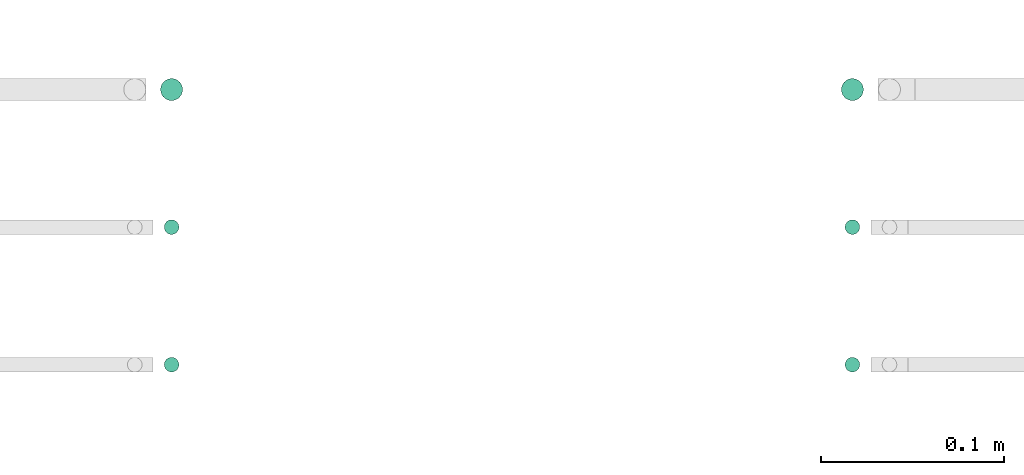
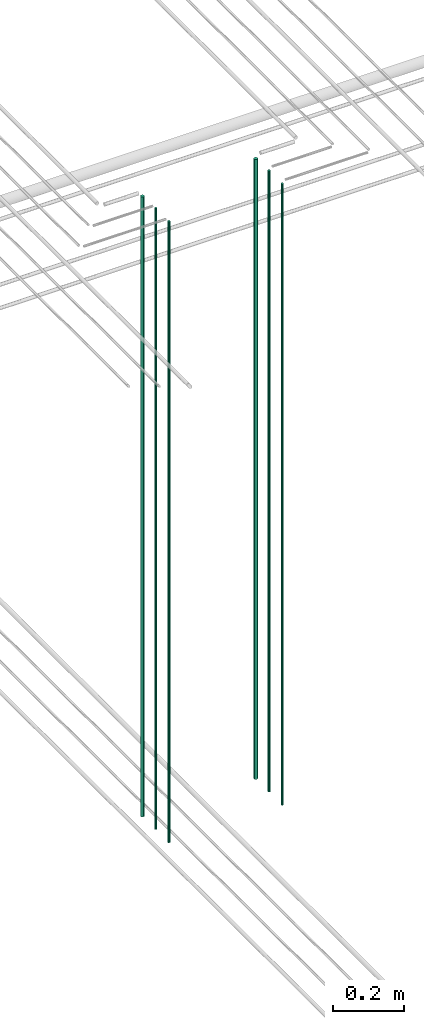
# One storey, part 11 of 331: 6 flow segments.
"""IFC2X3 building model written with IfcOpenShell, lengths in millimetres."""

import ifcopenshell
import ifcopenshell.guid

model = None  # the IFC model being written
_history = None  # IfcOwnerHistory: only IFC2X3 demands one
_inside = {}  # id of a spatial element -> (the spatial element, [elements in it])
_under = {}  # id of a project, library or spatial element -> (it, [spatial elements below it])
_declared = {}  # id of a project -> (the project, [libraries it declares])
_typed = {}  # id of a type object -> (the type object, [elements of that type])
_made_of = {}  # id of a material, layer set ... -> (it, [elements and type objects made of it])


def new_model(schema):
    """Start an empty IFC model of exactly this schema.

    Asked for "IFC4X3", IfcOpenShell would pick the latest addendum, in which some entities
    have other attributes; the version numbers below select the first issue.
    IFC2X3 requires an IfcOwnerHistory on every rooted entity: one is made here for all.
    """
    global model, _history
    if schema == "IFC4X3":
        model = ifcopenshell.file(schema_version=(4, 3, 0, 0))
    else:
        model = ifcopenshell.file(schema=schema)
    _inside.clear()
    _under.clear()
    _declared.clear()
    _typed.clear()
    _made_of.clear()
    _history = None
    if model.schema == "IFC2X3":
        org = make("IfcOrganization", Name="unknown")
        user = make(
            "IfcPersonAndOrganization",
            ThePerson=make("IfcPerson", FamilyName="unknown"),
            TheOrganization=org,
        )
        app = make(
            "IfcApplication",
            ApplicationDeveloper=org,
            Version="unknown",
            ApplicationFullName="unknown",
            ApplicationIdentifier="unknown",
        )
        _history = make(
            "IfcOwnerHistory",
            OwningUser=user,
            OwningApplication=app,
            ChangeAction="ADDED",
            CreationDate=0,
        )
    return model


def make(cls, **values):
    """One entity of the class cls with the attributes given. An attribute that is None is left unset."""
    return model.create_entity(
        cls, **{name: value for name, value in values.items() if value is not None}
    )


def entity(cls, *values):
    """Any entity or typed value of the class cls, its attributes in the order of the schema. None: left unset."""
    e = model.create_entity(cls)
    for i, value in enumerate(values):
        if value is not None:
            e[i] = value
    return e


def rooted(cls, **values):
    """An entity with a GlobalId (a new one), such as an element, a storey or a relation."""
    return make(cls, GlobalId=ifcopenshell.guid.new(), OwnerHistory=_history, **values)


def si_unit(unit_type, name, prefix=None):
    """IfcSIUnit, for example si_unit("LENGTHUNIT", "METRE", prefix="MILLI")."""
    return make("IfcSIUnit", UnitType=unit_type, Prefix=prefix, Name=name)


def converted_unit(unit_type, name, factor, base, dimensions=None, offset=None):
    """IfcConversionBasedUnit, such as the inch: factor (a typed value) times the base unit."""
    return make(
        "IfcConversionBasedUnit"
        if offset is None
        else "IfcConversionBasedUnitWithOffset",
        ConversionOffset=offset,
        Dimensions=None
        if dimensions is None
        else entity("IfcDimensionalExponents", *dimensions),
        UnitType=unit_type,
        Name=name,
        ConversionFactor=make(
            "IfcMeasureWithUnit", ValueComponent=factor, UnitComponent=base
        ),
    )


def derived_unit(unit_type, elements):
    """IfcDerivedUnit: a product of units, each with its exponent."""
    return make(
        "IfcDerivedUnit",
        Elements=[
            make("IfcDerivedUnitElement", Unit=unit, Exponent=power)
            for unit, power in elements
        ],
        UnitType=unit_type,
    )


def assignment(units):
    """IfcUnitAssignment: the units of a project."""
    return None if units is None else make("IfcUnitAssignment", Units=units)


def point(xyz):
    """IfcCartesianPoint."""
    return None if xyz is None else make("IfcCartesianPoint", Coordinates=xyz)


def direction(xyz):
    """IfcDirection."""
    return None if xyz is None else make("IfcDirection", DirectionRatios=xyz)


def frame(location, z_axis=None, x_axis=None):
    """IfcAxis2Placement3D, a coordinate frame: its origin and axes. An axis left out is left unset."""
    return make(
        "IfcAxis2Placement3D",
        Location=point(location),
        Axis=direction(z_axis),
        RefDirection=direction(x_axis),
    )


def frame_2d(location, x_axis=None):
    """IfcAxis2Placement2D, a coordinate frame in the plane: its origin and x axis."""
    return make(
        "IfcAxis2Placement2D", Location=point(location), RefDirection=direction(x_axis)
    )


def origin():
    """The frame at (0, 0, 0) with its axes left unset."""
    return frame((0.0, 0.0, 0.0))


def origin_2d_with_axis():
    """The frame at (0, 0) in the plane with the x axis (1, 0) written out."""
    return frame_2d((0.0, 0.0), x_axis=(1.0, 0.0))


def place(relative_to, where):
    """IfcLocalPlacement: puts the frame where relative to a parent placement (None: the world)."""
    return make(
        "IfcLocalPlacement", PlacementRelTo=relative_to, RelativePlacement=where
    )


def context(
    kind, dimensions, precision=None, world=None, true_north=None, identifier=None
):
    """IfcGeometricRepresentationContext, for example the 3D "Model" context."""
    return make(
        "IfcGeometricRepresentationContext",
        ContextIdentifier=identifier,
        ContextType=kind,
        CoordinateSpaceDimension=dimensions,
        Precision=precision,
        WorldCoordinateSystem=world,
        TrueNorth=true_north,
    )


def subcontext(parent, identifier, kind, view, scale=None):
    """IfcGeometricRepresentationSubContext, for example "Body" below "Model"."""
    return make(
        "IfcGeometricRepresentationSubContext",
        ContextIdentifier=identifier,
        ContextType=kind,
        ParentContext=parent,
        TargetScale=scale,
        TargetView=view,
    )


def project(units=None, contexts=None):
    """IfcProject with its units and contexts."""
    return rooted(
        "IfcProject",
        Name="project",
        RepresentationContexts=contexts,
        UnitsInContext=assignment(units),
    )


def spatial(cls, under=None, at=None, **own):
    """A site, building, storey or space (cls), placed at a placement, below another one or the project."""
    s = rooted(cls, ObjectPlacement=at, **own)
    if under is not None:
        _under.setdefault(under.id(), (under, []))[1].append(s)
    return s


def profile(cls, at=None, kind="AREA", **sizes):
    """A parametric profile (cls). Its sizes go by their IFC names, for example OverallWidth=200.0."""
    return make(cls, ProfileType=kind, Position=at, **sizes)


def circle(**sizes):
    """IfcCircleProfileDef."""
    return profile("IfcCircleProfileDef", **sizes)


def extrude(swept, where, along, depth):
    """IfcExtrudedAreaSolid: the profile swept, set in the frame where, extruded along a direction by depth."""
    return make(
        "IfcExtrudedAreaSolid",
        SweptArea=swept,
        Position=where,
        ExtrudedDirection=direction(along),
        Depth=depth,
    )


def shape(context_of_items, identifier, shape_type, items):
    """IfcShapeRepresentation: the items that make up one representation, for example the "Body"."""
    return make(
        "IfcShapeRepresentation",
        ContextOfItems=context_of_items,
        RepresentationIdentifier=identifier,
        RepresentationType=shape_type,
        Items=items,
    )


def made_of(thing, what):
    """Note that an element or type object is made of a material, layer set ...; save() writes the relation."""
    if what is not None:
        _made_of.setdefault(what.id(), (what, []))[1].append(thing)
    return thing


def type_object(cls, material=None, **own):
    """A type object (cls), such as IfcWallType, which elements share."""
    return made_of(rooted(cls, **own), material)


def element(
    cls,
    number,
    at=None,
    inside=None,
    cuts=None,
    type_object=None,
    material=None,
    context=None,
    identifier="Body",
    shape_type=None,
    held_by="IfcProductDefinitionShape",
    body=None,
    shapes=None,
    **own,
):
    """One element of the class cls, such as IfcWall. Its Tag is "e" and its number.

    at: its placement. inside: the storey or other place that contains it. cuts: it is an
    opening in that element (IfcRelVoidsElement). A single representation is given by context,
    identifier, shape_type and body (its items); several are given by shapes. held_by: the class
    of the entity that holds the representations. save() writes the other relations.
    """
    e = rooted(cls, Tag="e%d" % number, ObjectPlacement=at, **own)
    if body is not None:
        shapes = [shape(context, identifier, shape_type, body)]
    if shapes is not None:
        e.Representation = make(held_by, Representations=shapes)
    if inside is not None:
        _inside.setdefault(inside.id(), (inside, []))[1].append(e)
    if cuts is not None:
        rooted(
            "IfcRelVoidsElement", RelatingBuildingElement=cuts, RelatedOpeningElement=e
        )
    if type_object is not None:
        _typed.setdefault(type_object.id(), (type_object, []))[1].append(e)
    return made_of(e, material)


def aggregate(whole, parts):
    """IfcRelAggregates: a whole, such as a stair, and the parts it consists of."""
    return rooted("IfcRelAggregates", RelatingObject=whole, RelatedObjects=parts)


def save(model, path):
    """Write the relations noted so far, then the file.

    IfcRelAggregates (storeys below a building ...), IfcRelContainedInSpatialStructure (elements
    in a storey), IfcRelDefinesByType, IfcRelAssociatesMaterial and IfcRelDeclares: one each for
    every whole, place, type object, material and project.
    """
    for whole, parts in _under.values():
        aggregate(whole, parts)
    for where, things in _inside.values():
        rooted(
            "IfcRelContainedInSpatialStructure",
            RelatedElements=things,
            RelatingStructure=where,
        )
    for kind, things in _typed.values():
        rooted("IfcRelDefinesByType", RelatedObjects=things, RelatingType=kind)
    for what, things in _made_of.values():
        rooted("IfcRelAssociatesMaterial", RelatedObjects=things, RelatingMaterial=what)
    for by, libraries in _declared.values():
        rooted("IfcRelDeclares", RelatingContext=by, RelatedDefinitions=libraries)
    model.write(path)


model = new_model("IFC2X3")

# Units and contexts
model_context = context("Model", 3, precision=0.01, world=origin(), true_north=direction((6.12303176911189e-17, 1.0)))
body_context = subcontext(model_context, "Body", "Model", "MODEL_VIEW")
ifc_project = project(units=[si_unit("LENGTHUNIT", "METRE", prefix="MILLI"), si_unit("AREAUNIT", "SQUARE_METRE"), si_unit("VOLUMEUNIT", "CUBIC_METRE"), converted_unit("PLANEANGLEUNIT", "DEGREE", entity("IfcRatioMeasure", 0.0174532925199433), si_unit("PLANEANGLEUNIT", "RADIAN"), dimensions=[0, 0, 0, 0, 0, 0, 0]), si_unit("MASSUNIT", "GRAM", prefix="KILO"), derived_unit("MASSDENSITYUNIT", [(si_unit("MASSUNIT", "GRAM", prefix="KILO"), 1), (si_unit("LENGTHUNIT", "METRE"), -3)]), derived_unit("MOMENTOFINERTIAUNIT", [(si_unit("LENGTHUNIT", "METRE"), 4)]), si_unit("TIMEUNIT", "SECOND"), si_unit("FREQUENCYUNIT", "HERTZ"), si_unit("THERMODYNAMICTEMPERATUREUNIT", "DEGREE_CELSIUS"), derived_unit("THERMALTRANSMITTANCEUNIT", [(si_unit("MASSUNIT", "GRAM", prefix="KILO"), 1), (si_unit("THERMODYNAMICTEMPERATUREUNIT", "KELVIN"), -1), (si_unit("TIMEUNIT", "SECOND"), -3)]), derived_unit("VOLUMETRICFLOWRATEUNIT", [(si_unit("LENGTHUNIT", "METRE"), 3), (si_unit("TIMEUNIT", "SECOND"), -1)]), derived_unit("MASSFLOWRATEUNIT", [(si_unit("MASSUNIT", "GRAM", prefix="KILO"), 1), (si_unit("TIMEUNIT", "SECOND"), -1)]), derived_unit("ROTATIONALFREQUENCYUNIT", [(si_unit("TIMEUNIT", "SECOND"), -1)]), si_unit("ELECTRICCURRENTUNIT", "AMPERE"), si_unit("ELECTRICVOLTAGEUNIT", "VOLT"), si_unit("POWERUNIT", "WATT"), si_unit("FORCEUNIT", "NEWTON", prefix="KILO"), si_unit("ILLUMINANCEUNIT", "LUX"), si_unit("LUMINOUSFLUXUNIT", "LUMEN"), si_unit("LUMINOUSINTENSITYUNIT", "CANDELA"), derived_unit("USERDEFINED", [(si_unit("MASSUNIT", "GRAM", prefix="KILO"), -1), (si_unit("LENGTHUNIT", "METRE"), -2), (si_unit("TIMEUNIT", "SECOND"), 3), (si_unit("LUMINOUSFLUXUNIT", "LUMEN"), 1)]), derived_unit("LINEARVELOCITYUNIT", [(si_unit("LENGTHUNIT", "METRE"), 1), (si_unit("TIMEUNIT", "SECOND"), -1)]), si_unit("PRESSUREUNIT", "PASCAL"), derived_unit("USERDEFINED", [(si_unit("LENGTHUNIT", "METRE"), -2), (si_unit("MASSUNIT", "GRAM", prefix="KILO"), 1), (si_unit("TIMEUNIT", "SECOND"), -2)]), derived_unit("LINEARFORCEUNIT", [(si_unit("MASSUNIT", "GRAM", prefix="KILO"), 1), (si_unit("LENGTHUNIT", "METRE"), 1), (si_unit("TIMEUNIT", "SECOND"), -2), (si_unit("LENGTHUNIT", "METRE"), -1)]), derived_unit("PLANARFORCEUNIT", [(si_unit("MASSUNIT", "GRAM", prefix="KILO"), 1), (si_unit("LENGTHUNIT", "METRE"), 1), (si_unit("TIMEUNIT", "SECOND"), -2), (si_unit("LENGTHUNIT", "METRE"), -2)])], contexts=[model_context])

# Site, building, storey
site_placement = place(None, frame((0.0, -0.00077364408347762, 0.0)))
site = spatial("IfcSite", under=ifc_project, at=site_placement, CompositionType="ELEMENT")
building_placement = place(site_placement, origin())
building = spatial("IfcBuilding", under=site, at=building_placement, CompositionType="ELEMENT")
storey_placement = place(building_placement, origin())
storey = spatial("IfcBuildingStorey", under=building, at=storey_placement, CompositionType="ELEMENT", Elevation=0.0)

# Flow segments
pipe_segment_type = type_object("IfcPipeSegmentType", PredefinedType="NOTDEFINED")
flow_segment_1_placement = place(storey_placement, frame((25949.137938892, 3883.8934948431, 12990.0)))
element("IfcFlowSegment", 1, at=flow_segment_1_placement, inside=storey, type_object=pipe_segment_type, context=body_context, shape_type="SweptSolid", body=[
    extrude(circle(Radius=6.0, at=frame_2d((0.0, 5.41433564649196e-13), x_axis=(1.0, 0.0))), frame((7.59527223591454, 7.59527223591562, 0.0)), (0.0, 0.0, 1.0), 2145.99999999984),
])
for number, where in (
    (2, (25951.137938892, 3735.89349484291, 12990.0)),
    (3, (25951.137938892, 3810.89349484385, 12990.0)),
):
    element("IfcFlowSegment", number, at=place(storey_placement, frame(where)), inside=storey, type_object=pipe_segment_type, context=body_context, shape_type="SweptSolid", body=[
        extrude(circle(Radius=4.0, at=origin_2d_with_axis()), frame((5.59527223591499, 5.59527223591607, 0.0)), (0.0, 0.0, 1.0), 2150.00000000001),
    ])
flow_segment_2_placement = place(storey_placement, frame((25577.9067248322, 3883.89349484279, 12990.0)))
element("IfcFlowSegment", 4, at=flow_segment_2_placement, inside=storey, type_object=pipe_segment_type, context=body_context, shape_type="SweptSolid", body=[
    extrude(circle(Radius=6.0, at=frame_2d((0.0, 5.41433564649196e-13), x_axis=(1.0, 0.0))), frame((7.59527223591454, 7.59527223591562, 0.0)), (0.0, 0.0, 1.0), 2146.0),
])
for number, where in (
    (5, (25579.9067248322, 3735.89349484295, 12990.0)),
    (6, (25579.9067248322, 3810.89349484385, 12990.0)),
):
    element("IfcFlowSegment", number, at=place(storey_placement, frame(where)), inside=storey, type_object=pipe_segment_type, context=body_context, shape_type="SweptSolid", body=[
        extrude(circle(Radius=4.0, at=origin_2d_with_axis()), frame((5.59527223591499, 5.59527223591607, 0.0)), (0.0, 0.0, 1.0), 2150.00000000001),
    ])

save(model, "model.ifc")
